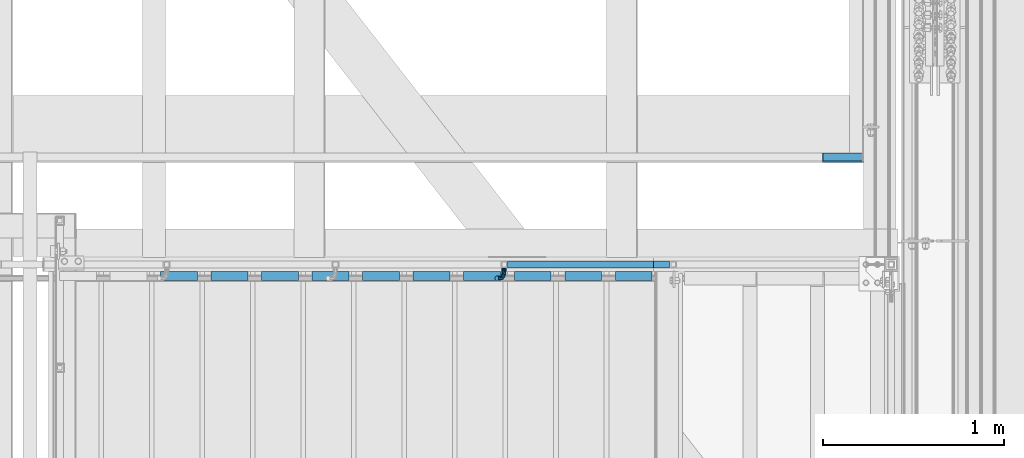
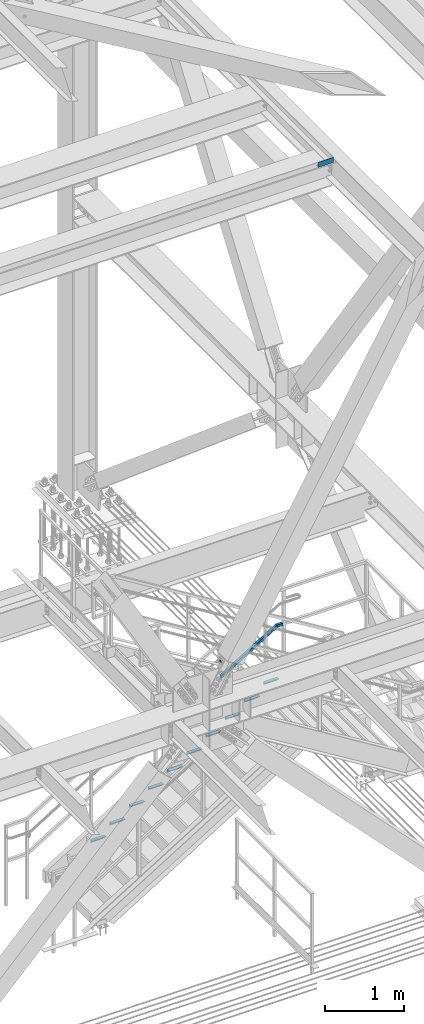
# One storey, part 2589 of 3843: 13 beams, 1 member, 3 elements without a shape of their own.
"""IFC2X3 building model written with IfcOpenShell, lengths in millimetres."""

from ifc_helpers import new_model, si_unit, frame, origin_with_axes, place, context, subcontext, project, spatial, faceted_brep, material, type_object, element, aggregate, save


model = new_model("IFC2X3")

# Units and contexts
model_context = context("Model", 3, precision=1e-05, world=origin_with_axes())
body_context = subcontext(model_context, "Body", "Model", "MODEL_VIEW")
ifc_project = project(units=[si_unit("LENGTHUNIT", "METRE", prefix="MILLI"), si_unit("AREAUNIT", "SQUARE_METRE"), si_unit("VOLUMEUNIT", "CUBIC_METRE"), si_unit("MASSUNIT", "GRAM", prefix="KILO"), si_unit("TIMEUNIT", "SECOND"), si_unit("PLANEANGLEUNIT", "RADIAN"), si_unit("SOLIDANGLEUNIT", "STERADIAN"), si_unit("THERMODYNAMICTEMPERATUREUNIT", "DEGREE_CELSIUS"), si_unit("LUMINOUSINTENSITYUNIT", "LUMEN")], contexts=[model_context])

# Site, building, storey
site_placement = place(None, origin_with_axes())
site = spatial("IfcSite", under=ifc_project, at=site_placement, CompositionType="ELEMENT")
building_placement = place(site_placement, origin_with_axes())
building = spatial("IfcBuilding", under=site, at=building_placement, Name="Undefined", CompositionType="ELEMENT")
storey_placement = place(building_placement, origin_with_axes())
storey = spatial("IfcBuildingStorey", under=building, at=storey_placement, Name="Undefined", CompositionType="ELEMENT", Elevation=0.0)

# Assembly, beam, member
assembly_1_placement = place(storey_placement, origin_with_axes())
assembly_1 = element("IfcElementAssembly", 1, at=assembly_1_placement, inside=storey, Name="RAIL", AssemblyPlace="NOTDEFINED", PredefinedType="RIGID_FRAME")
ifc_material_1 = material()
beam_type_1 = type_object("IfcBeamType", Name="HSS1-1/2X1-1/2X1/4", PredefinedType="NOTDEFINED")
beam_1_placement = place(assembly_1_placement, frame((84099.3999999465, 17919.7, 33248.5999999847), z_axis=(0.0, 0.0, 1.0), x_axis=(1.0, 0.0, 0.0)))
beam_1 = element("IfcBeam", 2, at=beam_1_placement, type_object=beam_type_1, material=ifc_material_1, Name="RAIL", ObjectType="HSS1-1/2X1-1/2X1/4", context=body_context, shape_type="Brep", body=[
    faceted_brep([(82.5500000532629, -19.0499999999993, 19.0499992350015), (82.5500000532629, -19.0499992350015, -19.0499992350015), (82.5500000532629, 19.0499992350015, -19.0499992350015), (82.5500000532629, 19.0499992350015, 19.0499992350015), (82.5500000532629, -12.6999993300014, 12.6999993299978), (82.5500000532629, 12.6999993300014, 12.6999993299978), (82.5500000532629, 12.6999993300014, -12.6999993299978), (82.5500000532629, -12.6999993300014, -12.6999993299978), (-5.39195348444628, 19.0499992350015, 19.0499992350015), (-5.39195348444628, -19.0499992350015, 19.0499992350015), (5.39195352466777, -19.0499992350015, -19.0499992350015), (5.39195352466777, 19.0499992350015, -19.0499992350015), (-3.59463560431323, 12.6999993300014, 12.6999993299978), (-3.59463560431323, -12.6999993300014, 12.6999993299978), (3.59463564452017, -12.6999993300014, -12.6999993299978), (3.59463564452017, 12.6999993300014, -12.6999993299978)], [[[0, 1, 2, 3], [4, 5, 6, 7]], [[8, 9, 0, 3]], [[10, 11, 2, 1]], [[9, 10, 1, 0]], [[11, 8, 3, 2]], [[10, 9, 8, 11], [12, 13, 14, 15]], [[14, 13, 4, 7]], [[15, 14, 7, 6]], [[12, 15, 6, 5]], [[13, 12, 5, 4]]]),
])
member_type = type_object("IfcMemberType", Name="HSS1-1/2X1-1/2X1/4", PredefinedType="NOTDEFINED")
member_placement = place(assembly_1_placement, frame((83267.5500000237, 17919.7, 32736.6923075648), z_axis=(-0.524097425775922, 0.0, 0.851658316635875), x_axis=(0.851658316635872, 0.0, 0.524097425775926)))
member = element("IfcMember", 3, at=member_placement, type_object=member_type, material=ifc_material_1, Name="RAIL", ObjectType="HSS1-1/2X1-1/2X1/4", context=body_context, shape_type="Brep", body=[
    faceted_brep([(10.6450480494532, -19.0499992350015, -19.0499992349796), (34.091200960931, -19.0499992350015, 19.0499992349942), (34.091200960931, 19.0499992350015, 19.0499992349942), (10.6450480494532, 19.0499992350015, -19.0499992349796), (30.1835087105574, 12.6999993300014, 12.6999993299978), (30.1835087105574, -12.6999993300014, 12.6999993299978), (14.5527402998268, -12.6999993300014, -12.6999993299833), (14.5527402998268, 12.6999993300014, -12.6999993299833), (971.349520950855, 19.0499992350015, -19.0499992344648), (971.349520950855, -19.0499992350015, -19.0499992344648), (982.133427982568, -19.0499992350015, 19.0499992355053), (982.133427982568, 19.0499992350015, 19.0499992355053), (980.336110098666, -12.6999993300014, 12.6999993305053), (980.336110098666, 12.6999993300014, 12.6999993305053), (973.146838834742, 12.6999993300014, -12.6999993294648), (973.146838834742, -12.6999993300014, -12.6999993294648)], [[[0, 1, 2, 3], [4, 5, 6, 7]], [[8, 9, 0, 3]], [[9, 10, 1, 0]], [[10, 11, 2, 1]], [[11, 8, 3, 2]], [[10, 9, 8, 11], [12, 13, 14, 15]], [[13, 12, 5, 4]], [[14, 13, 4, 7]], [[15, 14, 7, 6]], [[12, 15, 6, 5]]]),
])

# Assembly, beams
assembly_2_placement = place(storey_placement, origin_with_axes())
assembly_2 = element("IfcElementAssembly", 4, at=assembly_2_placement, inside=storey, Name="STAIR", AssemblyPlace="NOTDEFINED", PredefinedType="RIGID_FRAME")
ifc_material_2 = material(Name="STEEL/A572-50")
beam_type_2 = type_object("IfcBeamType", Name="L2X2X3/16", PredefinedType="NOTDEFINED")
beam_2_placement = place(assembly_2_placement, frame((83881.5140030485, 17856.1999999993, 32463.8865384615), z_axis=(0.0, -1.0, 0.0), x_axis=(1.0, 0.0, 0.0)))
beam_2 = element("IfcBeam", 5, at=beam_2_placement, type_object=beam_type_2, material=ifc_material_2, Name="ANGLE", ObjectType="L2X2X3/16", context=body_context, shape_type="Brep", body=[
    faceted_brep([(0.0, 25.4000000000015, -25.4000000000015), (0.0, 25.4000000000015, 25.4000000000015), (203.199999999997, 25.4000000000015, 25.4000000000015), (203.199999999997, 25.4000000000015, -25.4000000000015), (0.0, 20.6375000000007, 25.4000000000015), (203.199999999997, 20.6375000000007, 25.4000000000015), (0.0, 20.6375000000007, -20.6375000000007), (203.199999999997, 20.6375000000007, -20.6375000000007), (0.0, -25.4000000000015, -20.6375000000007), (203.199999999997, -25.4000000000015, -20.6375000000007), (0.0, -25.4000000000015, -25.4000000000015), (203.199999999997, -25.4000000000015, -25.4000000000015)], [[[0, 1, 2, 3]], [[1, 4, 5, 2]], [[4, 6, 7, 5]], [[6, 8, 9, 7]], [[8, 10, 11, 9]], [[10, 0, 3, 11]], [[5, 7, 9, 11, 3, 2]], [[10, 8, 6, 4, 1, 0]]]),
])
beam_3_placement = place(assembly_2_placement, frame((83602.1140030504, 17856.1999999907, 32291.9480769222), z_axis=(0.0, -1.0, 0.0), x_axis=(1.0, 0.0, 0.0)))
beam_3 = element("IfcBeam", 6, at=beam_3_placement, type_object=beam_type_2, material=ifc_material_2, Name="ANGLE", ObjectType="L2X2X3/16", context=body_context, shape_type="Brep", body=[
    faceted_brep([(0.0, 25.4000000000015, -25.4000000000015), (0.0, 25.4000000000015, 25.4000000000015), (203.199999999997, 25.4000000000015, 25.4000000000015), (203.199999999997, 25.4000000000015, -25.4000000000015), (0.0, 20.6375000000007, 25.4000000000015), (203.199999999997, 20.6375000000007, 25.4000000000015), (0.0, 20.6375000000007, -20.6375000000007), (203.199999999997, 20.6375000000007, -20.6375000000007), (0.0, -25.4000000000015, -20.6375000000007), (203.199999999997, -25.4000000000015, -20.6375000000007), (0.0, -25.4000000000015, -25.4000000000015), (203.199999999997, -25.4000000000015, -25.4000000000015)], [[[0, 1, 2, 3]], [[1, 4, 5, 2]], [[4, 6, 7, 5]], [[6, 8, 9, 7]], [[8, 10, 11, 9]], [[10, 0, 3, 11]], [[5, 7, 9, 11, 3, 2]], [[10, 8, 6, 4, 1, 0]]]),
])
beam_4_placement = place(assembly_2_placement, frame((83322.7140030504, 17856.1999999907, 32120.0096153838), z_axis=(0.0, -1.0, 0.0), x_axis=(1.0, 0.0, 0.0)))
beam_4 = element("IfcBeam", 7, at=beam_4_placement, type_object=beam_type_2, material=ifc_material_2, Name="ANGLE", ObjectType="L2X2X3/16", context=body_context, shape_type="Brep", body=[
    faceted_brep([(0.0, 25.4000000000015, -25.4000000000015), (0.0, 25.4000000000015, 25.4000000000015), (203.199999999997, 25.4000000000015, 25.4000000000015), (203.199999999997, 25.4000000000015, -25.4000000000015), (0.0, 20.6375000000007, 25.4000000000015), (203.199999999997, 20.6375000000007, 25.4000000000015), (0.0, 20.6375000000007, -20.6375000000007), (203.199999999997, 20.6375000000007, -20.6375000000007), (0.0, -25.4000000000015, -20.6375000000007), (203.199999999997, -25.4000000000015, -20.6375000000007), (0.0, -25.4000000000015, -25.4000000000015), (203.199999999997, -25.4000000000015, -25.4000000000015)], [[[0, 1, 2, 3]], [[1, 4, 5, 2]], [[4, 6, 7, 5]], [[6, 8, 9, 7]], [[8, 10, 11, 9]], [[10, 0, 3, 11]], [[5, 7, 9, 11, 3, 2]], [[10, 8, 6, 4, 1, 0]]]),
])
beam_5_placement = place(assembly_2_placement, frame((83043.3140030504, 17856.1999999907, 31948.0711538453), z_axis=(0.0, -1.0, 0.0), x_axis=(1.0, 0.0, 0.0)))
beam_5 = element("IfcBeam", 8, at=beam_5_placement, type_object=beam_type_2, material=ifc_material_2, Name="ANGLE", ObjectType="L2X2X3/16", context=body_context, shape_type="Brep", body=[
    faceted_brep([(0.0, 25.4000000000015, -25.4000000000015), (0.0, 25.4000000000015, 25.4000000000015), (203.199999999997, 25.4000000000015, 25.4000000000015), (203.199999999997, 25.4000000000015, -25.4000000000015), (0.0, 20.6375000000007, 25.4000000000015), (203.199999999997, 20.6375000000007, 25.4000000000015), (0.0, 20.6375000000007, -20.6375000000007), (203.199999999997, 20.6375000000007, -20.6375000000007), (0.0, -25.4000000000015, -20.6375000000007), (203.199999999997, -25.4000000000015, -20.6375000000007), (0.0, -25.4000000000015, -25.4000000000015), (203.199999999997, -25.4000000000015, -25.4000000000015)], [[[0, 1, 2, 3]], [[1, 4, 5, 2]], [[4, 6, 7, 5]], [[6, 8, 9, 7]], [[8, 10, 11, 9]], [[10, 0, 3, 11]], [[5, 7, 9, 11, 3, 2]], [[10, 8, 6, 4, 1, 0]]]),
])
beam_6_placement = place(assembly_2_placement, frame((82763.9140030504, 17856.1999999907, 31776.1326923068), z_axis=(0.0, -1.0, 0.0), x_axis=(1.0, 0.0, 0.0)))
beam_6 = element("IfcBeam", 9, at=beam_6_placement, type_object=beam_type_2, material=ifc_material_2, Name="ANGLE", ObjectType="L2X2X3/16", context=body_context, shape_type="Brep", body=[
    faceted_brep([(0.0, 25.4000000000015, -25.4000000000015), (0.0, 25.4000000000015, 25.4000000000015), (203.199999999997, 25.4000000000015, 25.4000000000015), (203.199999999997, 25.4000000000015, -25.4000000000015), (0.0, 20.6375000000007, 25.4000000000015), (203.199999999997, 20.6375000000007, 25.4000000000015), (0.0, 20.6375000000007, -20.6375000000007), (203.199999999997, 20.6375000000007, -20.6375000000007), (0.0, -25.4000000000015, -20.6375000000007), (203.199999999997, -25.4000000000015, -20.6375000000007), (0.0, -25.4000000000015, -25.4000000000015), (203.199999999997, -25.4000000000015, -25.4000000000015)], [[[0, 1, 2, 3]], [[1, 4, 5, 2]], [[4, 6, 7, 5]], [[6, 8, 9, 7]], [[8, 10, 11, 9]], [[10, 0, 3, 11]], [[5, 7, 9, 11, 3, 2]], [[10, 8, 6, 4, 1, 0]]]),
])
beam_7_placement = place(assembly_2_placement, frame((82484.5140030505, 17856.1999999907, 31604.1942307684), z_axis=(0.0, -1.0, 0.0), x_axis=(1.0, 0.0, 0.0)))
beam_7 = element("IfcBeam", 10, at=beam_7_placement, type_object=beam_type_2, material=ifc_material_2, Name="ANGLE", ObjectType="L2X2X3/16", context=body_context, shape_type="Brep", body=[
    faceted_brep([(0.0, 25.4000000000015, -25.4000000000015), (0.0, 25.4000000000015, 25.4000000000015), (203.199999999997, 25.4000000000015, 25.4000000000015), (203.199999999997, 25.4000000000015, -25.4000000000015), (0.0, 20.6375000000007, 25.4000000000015), (203.199999999997, 20.6375000000007, 25.4000000000015), (0.0, 20.6375000000007, -20.6375000000007), (203.199999999997, 20.6375000000007, -20.6375000000007), (0.0, -25.4000000000015, -20.6375000000007), (203.199999999997, -25.4000000000015, -20.6375000000007), (0.0, -25.4000000000015, -25.4000000000015), (203.199999999997, -25.4000000000015, -25.4000000000015)], [[[0, 1, 2, 3]], [[1, 4, 5, 2]], [[4, 6, 7, 5]], [[6, 8, 9, 7]], [[8, 10, 11, 9]], [[10, 0, 3, 11]], [[5, 7, 9, 11, 3, 2]], [[10, 8, 6, 4, 1, 0]]]),
])
beam_8_placement = place(assembly_2_placement, frame((82205.1140030505, 17856.1999999907, 31432.2557692299), z_axis=(0.0, -1.0, 0.0), x_axis=(1.0, 0.0, 0.0)))
beam_8 = element("IfcBeam", 11, at=beam_8_placement, type_object=beam_type_2, material=ifc_material_2, Name="ANGLE", ObjectType="L2X2X3/16", context=body_context, shape_type="Brep", body=[
    faceted_brep([(0.0, 25.4000000000015, -25.4000000000015), (0.0, 25.4000000000015, 25.4000000000015), (203.199999999997, 25.4000000000015, 25.4000000000015), (203.199999999997, 25.4000000000015, -25.4000000000015), (0.0, 20.6375000000007, 25.4000000000015), (203.199999999997, 20.6375000000007, 25.4000000000015), (0.0, 20.6375000000007, -20.6375000000007), (203.199999999997, 20.6375000000007, -20.6375000000007), (0.0, -25.4000000000015, -20.6375000000007), (203.199999999997, -25.4000000000015, -20.6375000000007), (0.0, -25.4000000000015, -25.4000000000015), (203.199999999997, -25.4000000000015, -25.4000000000015)], [[[0, 1, 2, 3]], [[1, 4, 5, 2]], [[4, 6, 7, 5]], [[6, 8, 9, 7]], [[8, 10, 11, 9]], [[10, 0, 3, 11]], [[5, 7, 9, 11, 3, 2]], [[10, 8, 6, 4, 1, 0]]]),
])
beam_9_placement = place(assembly_2_placement, frame((81925.7140030505, 17856.1999999907, 31260.3173076914), z_axis=(0.0, -1.0, 0.0), x_axis=(1.0, 0.0, 0.0)))
beam_9 = element("IfcBeam", 12, at=beam_9_placement, type_object=beam_type_2, material=ifc_material_2, Name="ANGLE", ObjectType="L2X2X3/16", context=body_context, shape_type="Brep", body=[
    faceted_brep([(0.0, 25.4000000000015, -25.4000000000015), (0.0, 25.4000000000015, 25.4000000000015), (203.199999999997, 25.4000000000015, 25.4000000000015), (203.199999999997, 25.4000000000015, -25.4000000000015), (0.0, 20.6375000000007, 25.4000000000015), (203.199999999997, 20.6375000000007, 25.4000000000015), (0.0, 20.6375000000007, -20.6375000000007), (203.199999999997, 20.6375000000007, -20.6375000000007), (0.0, -25.4000000000015, -20.6375000000007), (203.199999999997, -25.4000000000015, -20.6375000000007), (0.0, -25.4000000000015, -25.4000000000015), (203.199999999997, -25.4000000000015, -25.4000000000015)], [[[0, 1, 2, 3]], [[1, 4, 5, 2]], [[4, 6, 7, 5]], [[6, 8, 9, 7]], [[8, 10, 11, 9]], [[10, 0, 3, 11]], [[5, 7, 9, 11, 3, 2]], [[10, 8, 6, 4, 1, 0]]]),
])
beam_10_placement = place(assembly_2_placement, frame((81646.3140030505, 17856.1999999907, 31088.378846153), z_axis=(0.0, -1.0, 0.0), x_axis=(1.0, 0.0, 0.0)))
beam_10 = element("IfcBeam", 13, at=beam_10_placement, type_object=beam_type_2, material=ifc_material_2, Name="ANGLE", ObjectType="L2X2X3/16", context=body_context, shape_type="Brep", body=[
    faceted_brep([(0.0, 25.4000000000015, -25.4000000000015), (0.0, 25.4000000000015, 25.4000000000015), (203.199999999997, 25.4000000000015, 25.4000000000015), (203.199999999997, 25.4000000000015, -25.4000000000015), (0.0, 20.6375000000007, 25.4000000000015), (203.199999999997, 20.6375000000007, 25.4000000000015), (0.0, 20.6375000000007, -20.6375000000007), (203.199999999997, 20.6375000000007, -20.6375000000007), (0.0, -25.4000000000015, -20.6375000000007), (203.199999999997, -25.4000000000015, -20.6375000000007), (0.0, -25.4000000000015, -25.4000000000015), (203.199999999997, -25.4000000000015, -25.4000000000015)], [[[0, 1, 2, 3]], [[1, 4, 5, 2]], [[4, 6, 7, 5]], [[6, 8, 9, 7]], [[8, 10, 11, 9]], [[10, 0, 3, 11]], [[5, 7, 9, 11, 3, 2]], [[10, 8, 6, 4, 1, 0]]]),
])
beam_11_placement = place(assembly_2_placement, frame((81366.9140030505, 17856.1999999907, 30916.4403846145), z_axis=(0.0, -1.0, 0.0), x_axis=(1.0, 0.0, 0.0)))
beam_11 = element("IfcBeam", 14, at=beam_11_placement, type_object=beam_type_2, material=ifc_material_2, Name="ANGLE", ObjectType="L2X2X3/16", context=body_context, shape_type="Brep", body=[
    faceted_brep([(0.0, 25.4000000000015, -25.4000000000015), (0.0, 25.4000000000015, 25.4000000000015), (203.199999999997, 25.4000000000015, 25.4000000000015), (203.199999999997, 25.4000000000015, -25.4000000000015), (0.0, 20.6375000000007, 25.4000000000015), (203.199999999997, 20.6375000000007, 25.4000000000015), (0.0, 20.6375000000007, -20.6375000000007), (203.199999999997, 20.6375000000007, -20.6375000000007), (0.0, -25.4000000000015, -20.6375000000007), (203.199999999997, -25.4000000000015, -20.6375000000007), (0.0, -25.4000000000015, -25.4000000000015), (203.199999999997, -25.4000000000015, -25.4000000000015)], [[[0, 1, 2, 3]], [[1, 4, 5, 2]], [[4, 6, 7, 5]], [[6, 8, 9, 7]], [[8, 10, 11, 9]], [[10, 0, 3, 11]], [[5, 7, 9, 11, 3, 2]], [[10, 8, 6, 4, 1, 0]]]),
])
aggregate(assembly_2, [beam_2, beam_3, beam_4, beam_5, beam_6, beam_7, beam_8, beam_9, beam_10, beam_11])

# Beam
ifc_material_3 = material(Name="STEEL/A36")
beam_type_3 = type_object("IfcBeamType", PredefinedType="NOTDEFINED")
beam_12_placement = place(assembly_1_placement, frame((83265.7516850376, 17900.65, 33004.7450254949), z_axis=(-0.851658316635875, 0.0, -0.524097425775922), x_axis=(0.0, -1.0, 0.0)))
beam_12 = element("IfcBeam", 15, at=beam_12_placement, type_object=beam_type_3, material=ifc_material_3, Name="BRACKET ARM", context=body_context, shape_type="Brep", body=[
    faceted_brep([(0.0, -12.6999999999971, 0.0), (0.0, -10.9985226280696, -6.34999999999854), (19.0500015258731, -10.9985226280623, -6.34999999999854), (19.0500015258731, -12.6999999999971, -6.33008312433958e-10), (0.0, -6.35000000000582, -10.9985226280623), (19.0500015258731, -6.34999999999854, -10.9985226280623), (0.0, 0.0, -12.6999999999971), (19.0500015258731, 0.0, -12.6999999999971), (0.0, 6.35000000000582, -10.9985226280623), (19.0500015258731, 6.34999999999854, -10.9985226280623), (0.0, 10.9985226280696, -6.34999999999854), (19.0500015258731, 10.9985226280623, -6.34999999999854), (0.0, 12.6999999999971, 0.0), (19.0500015258731, 12.6999999999971, 0.0), (0.0, 10.9985226280696, 6.34999999999854), (19.0500015258731, 10.9985226280623, 6.34999999999854), (0.0, 6.35000000000582, 10.9985226280623), (19.0500015258731, 6.34999999999854, 10.9985226280623), (0.0, 0.0, 12.6999999999971), (19.0500015258731, 0.0, 12.6999999999971), (0.0, -6.35000000000582, 10.9985226280623), (19.0500015258731, -6.34999999999854, 10.9985226280623), (0.0, -10.9985226280696, 6.34999999999854), (19.0500015258731, -10.9985226280623, 6.34999999999854), (38.4903193060891, -8.8330803677236, -3.34694050252438e-10), (37.8391921052389, -7.26112024908798, 6.34999999974389), (36.0602795104642, -2.96644533684594, 10.9985226280041), (33.6302397149266, 2.90018969451194, 12.7000000002226), (31.2001999194181, 8.76682472604443, 10.9985226285644), (29.4212873247307, 13.061499638774, 6.35000000070431), (28.7701601240115, 14.6334597580644, 7.78527464717627e-10), (29.4212873248762, 13.0614996394288, -6.34999999929278), (31.2001999196509, 8.76682472718676, -10.9985226275603), (33.6302397151885, 2.90018969582889, -12.6999999997788), (36.0602795106824, -2.96644533571089, -10.9985226281206), (37.8391921053699, -7.26112024843314, -6.35000000026048), (53.7678987435793, 3.38210125690239, -6.3499999994383), (54.9710249311902, 2.17897506880399, 5.0931703299284e-10), (50.4808968708676, 6.66910312997061, -10.9985226273784), (45.9907688103704, 11.1592311906061, -12.6999999991458), (41.5006407498004, 15.6493592510378, -10.9985226270364), (38.213638876914, 18.9363611235749, -6.34999999884167), (37.0105126890558, 20.1394873109457, 1.20053300634027e-09), (38.2136388766667, 18.9363611228473, 6.35000000115542), (41.5006407493784, 15.6493592497718, 10.9985226290883), (45.9907688098756, 11.1592311891436, 12.7000000008557), (50.4808968704456, 6.66910312870459, 10.9985226287463), (53.7678987433319, 3.38210125617479, 6.35000000055879), (64.4111202489148, 19.3108078951118, -6.34999999821594), (65.9830803677178, 18.6596806939051, 1.77533365786076e-09), (60.1164453365491, 21.0897204901557, -10.9985226262725), (54.2498103051475, 23.5197602857806, -12.6999999981927), (48.3831752736587, 25.9498000811873, -10.9985226262434), (44.0885003610601, 27.7287126756128, -6.34999999817228), (42.516540241937, 28.3798398759754, 1.83354131877422e-09), (44.08850036074, 27.7287126747688, 6.35000000183209), (48.3831752731057, 25.9498000797321, 10.9985226298813), (54.2498103045073, 23.5197602840999, 12.7000000018088), (60.1164453359961, 21.0897204886933, 10.9985226298522), (64.4111202485947, 19.3108078942678, 6.35000000178115), (68.1485226282239, 38.0999984746086, -6.3499999967753), (69.8499999999913, 38.0999984741211, 2.92493496090174e-09), (63.500000000291, 38.0999984749651, -10.9985226249628), (57.1500000003434, 38.0999984750961, -12.6999999970722), (50.8000000002939, 38.0999984749651, -10.998522625312), (46.1514773720992, 38.0999984746086, -6.34999999737192), (44.4499999999971, 38.0999984741211, 2.58296495303512e-09), (46.1514773717645, 38.0999984736336, 6.35000000262517), (50.7999999996973, 38.0999984732771, 10.9985226308127), (57.1499999996449, 38.0999984731461, 12.700000002922), (63.4999999996944, 38.0999984732771, 10.9985226311619), (68.1485226278892, 38.0999984736336, 6.35000000322179), (68.1485226280638, 76.2000000002372, -6.34999999414867), (69.8499999999913, 76.199999999757, 5.84986992180347e-09), (63.5, 76.200000000601, -10.9985226222125), (57.1499999999942, 76.2000000007247, -12.6999999941472), (50.7999999999884, 76.200000000601, -10.9985226222125), (46.1514773719246, 76.2000000002372, -6.34999999414867), (44.4499999999971, 76.199999999757, 5.84986992180347e-09), (46.1514773719246, 76.1999999992695, 6.35000000584841), (50.7999999999884, 76.1999999989057, 10.9985226339122), (57.1499999999942, 76.199999998782, 12.700000005847), (63.5, 76.1999999989057, 10.9985226339122), (68.1485226280638, 76.1999999992695, 6.35000000584841)], [[[0, 1, 2, 3]], [[1, 4, 5, 2]], [[4, 6, 7, 5]], [[6, 8, 9, 7]], [[8, 10, 11, 9]], [[10, 12, 13, 11]], [[12, 14, 15, 13]], [[14, 16, 17, 15]], [[16, 18, 19, 17]], [[18, 20, 21, 19]], [[20, 22, 23, 21]], [[22, 0, 3, 23]], [[22, 20, 18, 16, 14, 12, 10, 8, 6, 4, 1, 0]], [[23, 3, 24, 25]], [[21, 23, 25, 26]], [[19, 21, 26, 27]], [[17, 19, 27, 28]], [[15, 17, 28, 29]], [[13, 15, 29, 30]], [[11, 13, 30, 31]], [[9, 11, 31, 32]], [[7, 9, 32, 33]], [[5, 7, 33, 34]], [[2, 5, 34, 35]], [[3, 2, 35, 24]], [[35, 36, 37, 24]], [[34, 38, 36, 35]], [[33, 39, 38, 34]], [[32, 40, 39, 33]], [[31, 41, 40, 32]], [[30, 42, 41, 31]], [[29, 43, 42, 30]], [[28, 44, 43, 29]], [[27, 45, 44, 28]], [[26, 46, 45, 27]], [[25, 47, 46, 26]], [[24, 37, 47, 25]], [[36, 48, 49, 37]], [[38, 50, 48, 36]], [[39, 51, 50, 38]], [[40, 52, 51, 39]], [[41, 53, 52, 40]], [[42, 54, 53, 41]], [[43, 55, 54, 42]], [[44, 56, 55, 43]], [[45, 57, 56, 44]], [[46, 58, 57, 45]], [[47, 59, 58, 46]], [[37, 49, 59, 47]], [[48, 60, 61, 49]], [[50, 62, 60, 48]], [[51, 63, 62, 50]], [[52, 64, 63, 51]], [[53, 65, 64, 52]], [[54, 66, 65, 53]], [[55, 67, 66, 54]], [[56, 68, 67, 55]], [[57, 69, 68, 56]], [[58, 70, 69, 57]], [[59, 71, 70, 58]], [[49, 61, 71, 59]], [[61, 60, 72, 73]], [[60, 62, 74, 72]], [[62, 63, 75, 74]], [[63, 64, 76, 75]], [[64, 65, 77, 76]], [[65, 66, 78, 77]], [[66, 67, 79, 78]], [[67, 68, 80, 79]], [[68, 69, 81, 80]], [[69, 70, 82, 81]], [[70, 71, 83, 82]], [[71, 61, 73, 83]], [[74, 75, 76, 77, 78, 79, 80, 81, 82, 83, 73, 72]]]),
])

aggregate(assembly_1, [beam_1, member, beam_12])

# Assembly, beam
assembly_3_placement = place(storey_placement, origin_with_axes())
assembly_3 = element("IfcElementAssembly", 16, at=assembly_3_placement, inside=storey, Name="BEAM", AssemblyPlace="NOTDEFINED", PredefinedType="RIGID_FRAME")
beam_type_4 = type_object("IfcBeamType", PredefinedType="NOTDEFINED")
beam_13_placement = place(assembly_3_placement, frame((85140.80025, 18535.65, 39627.175), z_axis=(-1.0, 0.0, 0.0), x_axis=(0.0, -1.0, 0.0)))
beam_13 = element("IfcBeam", 17, at=beam_13_placement, type_object=beam_type_4, material=ifc_material_3, Name="BENT_PLATE", context=body_context, shape_type="Brep", body=[
    faceted_brep([(0.0, 3.17500000000291, 109.538000047687), (0.0, -4.76939021609724e-08, 112.713000000003), (47.6249999522843, -4.76939021609724e-08, 112.713000000003), (44.4500000000007, 3.17500000000291, 109.538000047687), (47.6249999523097, 73.0249999999942, 112.713000000003), (44.4500000000007, 73.0249999999942, 109.538000047687), (44.4500000000007, 73.0249999999942, -112.713000000003), (44.4500000000007, 3.17500000000291, -112.713000000003), (0.0, 3.17500000000291, -112.713000000003), (0.0, -3.17500000000291, -112.713000000003), (0.0, -3.17500000000291, 112.713000000003), (50.7999999999993, -3.17500000000291, -112.713000000003), (50.7999999999993, -3.17500000000291, 112.713000000003), (50.7999999999993, 73.0249999999942, 112.713000000003), (50.7999999999993, 73.0249999999942, -112.713000000003)], [[[0, 1, 2, 3]], [[3, 2, 4, 5]], [[6, 7, 3, 5]], [[8, 9, 10, 1, 0]], [[7, 8, 0, 3]], [[10, 9, 11, 12]], [[1, 10, 12, 13, 4, 2]], [[12, 11, 14, 13]], [[11, 9, 8, 7, 6, 14]], [[13, 14, 6, 5, 4]]]),
])
aggregate(assembly_3, [beam_13])

save(model, "model.ifc")
